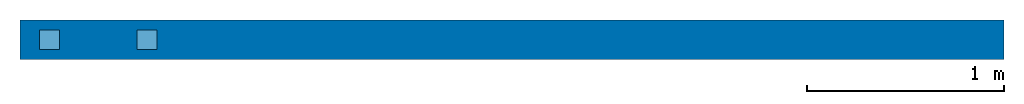
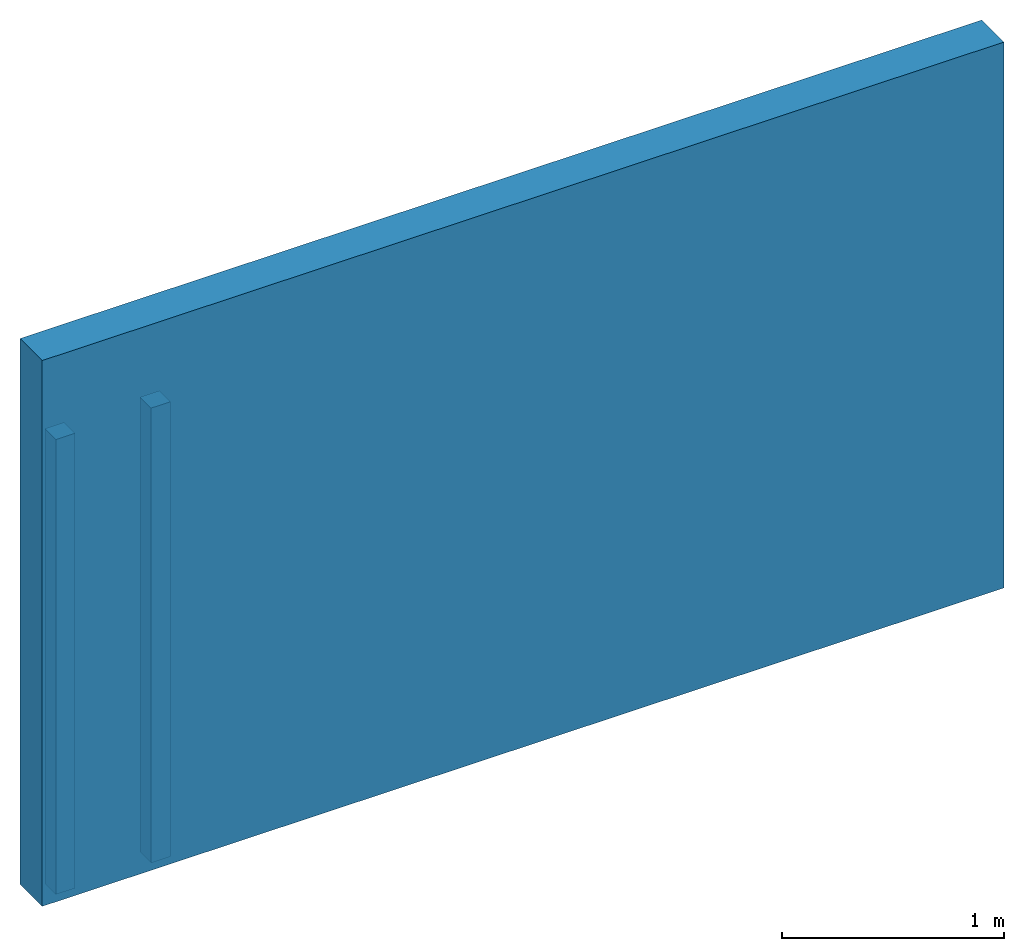
# One storey: 2 members, 1 wall.
"""IFC4 building model written with IfcOpenShell, lengths in metres."""

from ifc_helpers import new_model, entity, si_unit, converted_unit, direction, frame, origin_with_axes, place, context, project, spatial, polyline, outline, extrude, material, layer, layer_set, layer_usage, element, save


model = new_model("IFC4")

# Units and contexts
model_context = context("Model", 3, precision=1e-05, world=origin_with_axes(), true_north=direction((0.0, 1.0, 0.0)))
ifc_project = project(units=[si_unit("LENGTHUNIT", "METRE"), si_unit("AREAUNIT", "SQUARE_METRE"), si_unit("VOLUMEUNIT", "CUBIC_METRE"), converted_unit("PLANEANGLEUNIT", "DEGREE", entity("IfcPlaneAngleMeasure", 0.017453292519943295), si_unit("PLANEANGLEUNIT", "RADIAN"), dimensions=[0, 0, 0, 0, 0, 0, 0])], contexts=[model_context])

# Site, building, storey
site_placement = place(None, origin_with_axes())
site = spatial("IfcSite", under=ifc_project, at=site_placement, CompositionType="ELEMENT")
building_placement = place(site_placement, origin_with_axes())
building = spatial("IfcBuilding", under=site, at=building_placement, Name="Building", CompositionType="ELEMENT")
storey_placement = place(building_placement, origin_with_axes())
storey = spatial("IfcBuildingStorey", under=building, at=storey_placement, Name="Storey", CompositionType="ELEMENT", Elevation=0.0)

# Members
ifc_material_1 = material(Name="spruce")
placement = place(storey_placement, origin_with_axes())
element("IfcMember", 1, at=placement, inside=storey, material=ifc_material_1, Name="Member", ObjectType="STUD", context=model_context, shape_type="SweptSolid", body=[
    extrude(outline(polyline([(0.0, -0.05), (0.1, -0.05), (0.1, 0.05), (0.0, 0.05), (0.0, -0.05)])), frame((0.1, 0.0, 0.0), z_axis=(0.0, 0.0, 1.0), x_axis=(1.0, 0.0, 0.0)), (0.0, 0.0, 1.0), 2.5),
])
element("IfcMember", 2, at=placement, inside=storey, material=ifc_material_1, Name="Member", ObjectType="STUD", context=model_context, shape_type="SweptSolid", body=[
    extrude(outline(polyline([(0.0, -0.05), (0.1, -0.05), (0.1, 0.05), (0.0, 0.05), (0.0, -0.05)])), frame((0.595, 0.0, 0.0), z_axis=(0.0, 0.0, 1.0), x_axis=(1.0, 0.0, 0.0)), (0.0, 0.0, 1.0), 2.5),
])

# Wall
ifc_material_2 = material(Name="CLT")
ifc_layer = layer(ifc_material_2, 0.2)
ifc_layer_set = layer_set([ifc_layer])
ifc_layer_usage = layer_usage(ifc_layer_set, "AXIS2", "POSITIVE", -0.1)
wall_placement = place(storey_placement, origin_with_axes())
element("IfcWall", 3, at=wall_placement, inside=storey, material=ifc_layer_usage, Name="Wall", context=model_context, shape_type="SweptSolid", body=[
    extrude(outline(polyline([(0.0, -0.1), (5.0, -0.1), (5.0, 0.1), (0.0, 0.1), (0.0, -0.1)])), origin_with_axes(), (0.0, 0.0, 1.0), 3.0),
])

save(model, "model.ifc")
